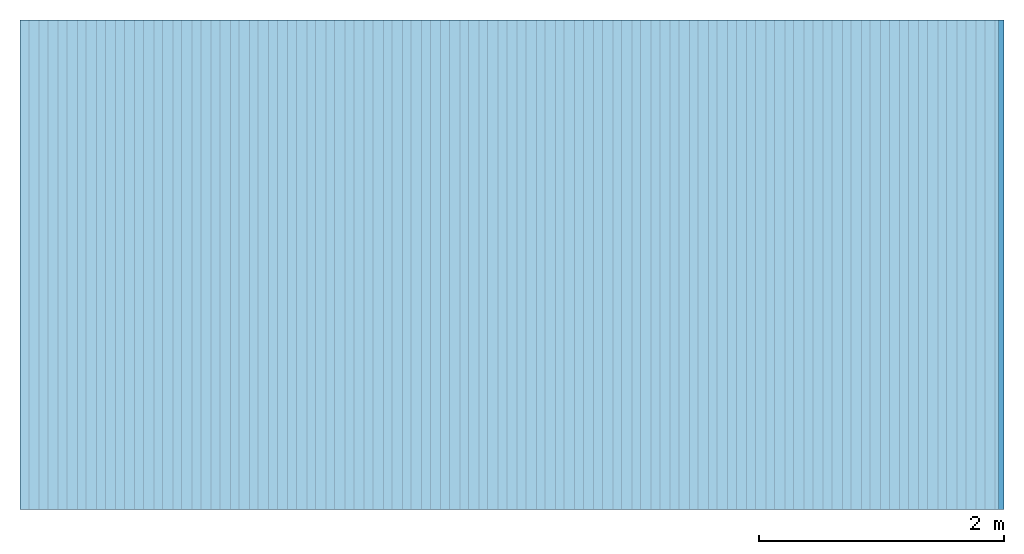
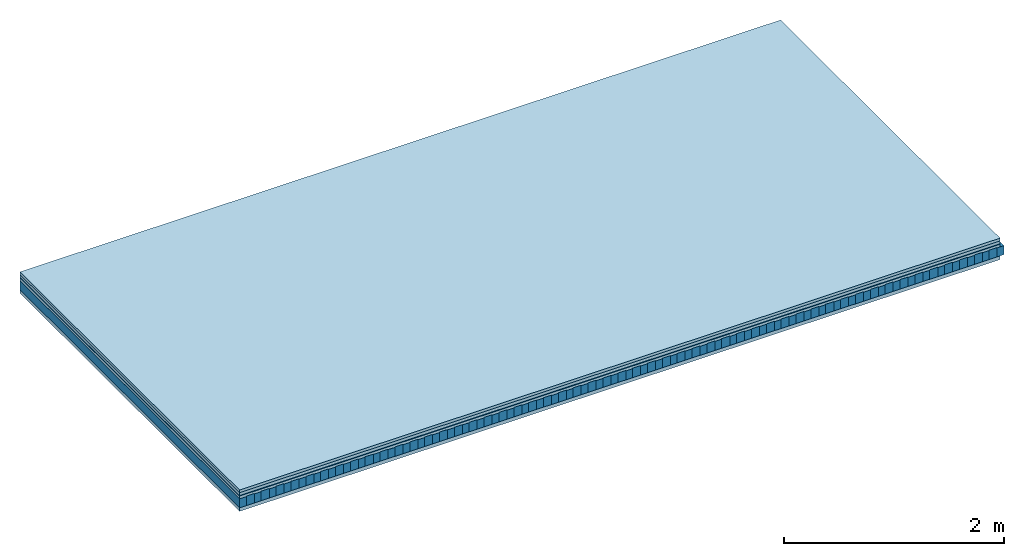
# One storey: 5 plates, 2 members, 1 element without a shape of its own.
"""IFC4 building model written with IfcOpenShell, lengths in metres."""

from ifc_helpers import new_model, si_unit, derived_unit, direction, frame, frame_2d, origin, origin_with_axes, place, context, project, spatial, rectangle, extrude, material, layer, layer_set, type_object, element, aggregate, save


model = new_model("IFC4")

# Units and contexts
plan_context = context("Plan", 3, precision=1e-05, world=origin(), true_north=direction((0.0, 1.0)))
model_context = context("Model", 3, precision=1e-05, world=origin(), true_north=direction((0.0, 1.0)))
ifc_project = project(units=[si_unit("LENGTHUNIT", "METRE"), derived_unit("SOUNDPRESSUREUNIT", [(si_unit("PRESSUREUNIT", "PASCAL", prefix="MICRO"), 0)]), si_unit("ENERGYUNIT", "JOULE", prefix="MEGA"), si_unit("MASSUNIT", "GRAM", prefix="KILO"), derived_unit("THERMALTRANSMITTANCEUNIT", [(si_unit("POWERUNIT", "WATT"), 1), (si_unit("AREAUNIT", "SQUARE_METRE"), -1), (si_unit("THERMODYNAMICTEMPERATUREUNIT", "KELVIN"), -1)]), derived_unit("AREADENSITYUNIT", [(si_unit("MASSUNIT", "GRAM", prefix="KILO"), 1), (si_unit("AREAUNIT", "SQUARE_METRE"), -1)]), derived_unit("USERDEFINED", [(si_unit("ENERGYUNIT", "JOULE", prefix="MEGA"), 1), (si_unit("AREAUNIT", "SQUARE_METRE"), -1)])], contexts=[plan_context, model_context])

# Site, building, storey
site = spatial("IfcSite", under=ifc_project)
building_placement = place(None, origin())
building = spatial("IfcBuilding", under=site, at=building_placement)
storey_placement = place(building_placement, origin())
storey = spatial("IfcBuildingStorey", under=building, at=storey_placement)

# Slab, members, plates
ifc_material_1 = material(Category="10.009")
ifc_layer_1 = layer(ifc_material_1, 0.03, Name="On-material")
ifc_material_2 = material(Name="32/30mm", Category="10.009")
ifc_layer_2 = layer(ifc_material_2, 0.032, Name="Impact sound insulation")
ifc_material_3 = material(Name="Step 6mm", Category="10.009")
ifc_layer_3 = layer(ifc_material_3, 0.006, Name="Additional insulation")
ifc_material_4 = material()
ifc_layer_4 = layer(ifc_material_4, 0.03, Name="Sub-floor")
ifc_material_5 = material(Name="Rigid, of the art")
ifc_layer_5 = layer(ifc_material_5, 0.0, Name="Bond")
ifc_layer_6 = layer(None, 0.1, Name="Supporting structure")
ifc_layer_7 = layer(ifc_material_5, 0.0, Name="Bond")
ifc_material_6 = material(Name="panel on the underside HBF 40mm (20+20mm)", Category="07.001")
ifc_layer_8 = layer(ifc_material_6, 0.04, Name="Lower layer 1")
ifc_layer_set = layer_set([ifc_layer_1, ifc_layer_2, ifc_layer_3, ifc_layer_4, ifc_layer_5, ifc_layer_6, ifc_layer_7, ifc_layer_8])
slab_type = type_object("IfcSlabType", Name="A0083", PredefinedType="NOTDEFINED", material=ifc_layer_set)
slab_placement = place(None, frame((0.0, 0.0, 0.0), z_axis=(0.0, 0.0, -1.0), x_axis=(1.0, 0.0, 0.0)))
slab = element("IfcSlab", 1, at=slab_placement, inside=storey, type_object=slab_type, material=ifc_layer_set, Name="Slab #1")
ifc_material_7 = material(Name="Block Q4")
member_1_placement = place(slab_placement, origin())
member_1 = element("IfcMember", 2, at=member_1_placement, material=ifc_material_7, Name="Supporting structure", context=plan_context, shape_type="SweptSolid", body=[
    extrude(rectangle(XDim=0.071666666666667, YDim=0.1, at=frame_2d((0.0358333333333335, 0.05), x_axis=(1.0, 0.0))), frame((0.0, 4.0, 0.098), z_axis=(0.0, -1.0, 0.0), x_axis=(1.0, 0.0, 0.0)), (0.0, 0.0, 1.0), 4.0),
    extrude(rectangle(XDim=0.071666666666667, YDim=0.1, at=frame_2d((0.0358333333333335, 0.05), x_axis=(1.0, 0.0))), frame((0.15625, 4.0, 0.098), z_axis=(0.0, -1.0, 0.0), x_axis=(1.0, 0.0, 0.0)), (0.0, 0.0, 1.0), 4.0),
    extrude(rectangle(XDim=0.071666666666667, YDim=0.1, at=frame_2d((0.0358333333333335, 0.05), x_axis=(1.0, 0.0))), frame((0.3125, 4.0, 0.098), z_axis=(0.0, -1.0, 0.0), x_axis=(1.0, 0.0, 0.0)), (0.0, 0.0, 1.0), 4.0),
    extrude(rectangle(XDim=0.071666666666667, YDim=0.1, at=frame_2d((0.0358333333333335, 0.05), x_axis=(1.0, 0.0))), frame((0.46875, 4.0, 0.098), z_axis=(0.0, -1.0, 0.0), x_axis=(1.0, 0.0, 0.0)), (0.0, 0.0, 1.0), 4.0),
    extrude(rectangle(XDim=0.071666666666667, YDim=0.1, at=frame_2d((0.0358333333333335, 0.05), x_axis=(1.0, 0.0))), frame((0.625, 4.0, 0.098), z_axis=(0.0, -1.0, 0.0), x_axis=(1.0, 0.0, 0.0)), (0.0, 0.0, 1.0), 4.0),
    extrude(rectangle(XDim=0.071666666666667, YDim=0.1, at=frame_2d((0.0358333333333335, 0.05), x_axis=(1.0, 0.0))), frame((0.78125, 4.0, 0.098), z_axis=(0.0, -1.0, 0.0), x_axis=(1.0, 0.0, 0.0)), (0.0, 0.0, 1.0), 4.0),
    extrude(rectangle(XDim=0.071666666666667, YDim=0.1, at=frame_2d((0.0358333333333335, 0.05), x_axis=(1.0, 0.0))), frame((0.9375, 4.0, 0.098), z_axis=(0.0, -1.0, 0.0), x_axis=(1.0, 0.0, 0.0)), (0.0, 0.0, 1.0), 4.0),
    extrude(rectangle(XDim=0.071666666666667, YDim=0.1, at=frame_2d((0.0358333333333335, 0.05), x_axis=(1.0, 0.0))), frame((1.09375, 4.0, 0.098), z_axis=(0.0, -1.0, 0.0), x_axis=(1.0, 0.0, 0.0)), (0.0, 0.0, 1.0), 4.0),
    extrude(rectangle(XDim=0.071666666666667, YDim=0.1, at=frame_2d((0.0358333333333335, 0.05), x_axis=(1.0, 0.0))), frame((1.25, 4.0, 0.098), z_axis=(0.0, -1.0, 0.0), x_axis=(1.0, 0.0, 0.0)), (0.0, 0.0, 1.0), 4.0),
    extrude(rectangle(XDim=0.071666666666667, YDim=0.1, at=frame_2d((0.0358333333333335, 0.05), x_axis=(1.0, 0.0))), frame((1.40625, 4.0, 0.098), z_axis=(0.0, -1.0, 0.0), x_axis=(1.0, 0.0, 0.0)), (0.0, 0.0, 1.0), 4.0),
    extrude(rectangle(XDim=0.071666666666667, YDim=0.1, at=frame_2d((0.0358333333333335, 0.05), x_axis=(1.0, 0.0))), frame((1.5625, 4.0, 0.098), z_axis=(0.0, -1.0, 0.0), x_axis=(1.0, 0.0, 0.0)), (0.0, 0.0, 1.0), 4.0),
    extrude(rectangle(XDim=0.071666666666667, YDim=0.1, at=frame_2d((0.0358333333333335, 0.05), x_axis=(1.0, 0.0))), frame((1.71875, 4.0, 0.098), z_axis=(0.0, -1.0, 0.0), x_axis=(1.0, 0.0, 0.0)), (0.0, 0.0, 1.0), 4.0),
    extrude(rectangle(XDim=0.071666666666667, YDim=0.1, at=frame_2d((0.0358333333333335, 0.05), x_axis=(1.0, 0.0))), frame((1.875, 4.0, 0.098), z_axis=(0.0, -1.0, 0.0), x_axis=(1.0, 0.0, 0.0)), (0.0, 0.0, 1.0), 4.0),
    extrude(rectangle(XDim=0.071666666666667, YDim=0.1, at=frame_2d((0.0358333333333335, 0.05), x_axis=(1.0, 0.0))), frame((2.03125, 4.0, 0.098), z_axis=(0.0, -1.0, 0.0), x_axis=(1.0, 0.0, 0.0)), (0.0, 0.0, 1.0), 4.0),
    extrude(rectangle(XDim=0.071666666666667, YDim=0.1, at=frame_2d((0.0358333333333335, 0.05), x_axis=(1.0, 0.0))), frame((2.1875, 4.0, 0.098), z_axis=(0.0, -1.0, 0.0), x_axis=(1.0, 0.0, 0.0)), (0.0, 0.0, 1.0), 4.0),
    extrude(rectangle(XDim=0.071666666666667, YDim=0.1, at=frame_2d((0.0358333333333335, 0.05), x_axis=(1.0, 0.0))), frame((2.34375, 4.0, 0.098), z_axis=(0.0, -1.0, 0.0), x_axis=(1.0, 0.0, 0.0)), (0.0, 0.0, 1.0), 4.0),
    extrude(rectangle(XDim=0.071666666666667, YDim=0.1, at=frame_2d((0.0358333333333335, 0.05), x_axis=(1.0, 0.0))), frame((2.5, 4.0, 0.098), z_axis=(0.0, -1.0, 0.0), x_axis=(1.0, 0.0, 0.0)), (0.0, 0.0, 1.0), 4.0),
    extrude(rectangle(XDim=0.071666666666667, YDim=0.1, at=frame_2d((0.0358333333333335, 0.05), x_axis=(1.0, 0.0))), frame((2.65625, 4.0, 0.098), z_axis=(0.0, -1.0, 0.0), x_axis=(1.0, 0.0, 0.0)), (0.0, 0.0, 1.0), 4.0),
    extrude(rectangle(XDim=0.071666666666667, YDim=0.1, at=frame_2d((0.0358333333333335, 0.05), x_axis=(1.0, 0.0))), frame((2.8125, 4.0, 0.098), z_axis=(0.0, -1.0, 0.0), x_axis=(1.0, 0.0, 0.0)), (0.0, 0.0, 1.0), 4.0),
    extrude(rectangle(XDim=0.071666666666667, YDim=0.1, at=frame_2d((0.0358333333333335, 0.05), x_axis=(1.0, 0.0))), frame((2.96875, 4.0, 0.098), z_axis=(0.0, -1.0, 0.0), x_axis=(1.0, 0.0, 0.0)), (0.0, 0.0, 1.0), 4.0),
    extrude(rectangle(XDim=0.071666666666667, YDim=0.1, at=frame_2d((0.0358333333333335, 0.05), x_axis=(1.0, 0.0))), frame((3.125, 4.0, 0.098), z_axis=(0.0, -1.0, 0.0), x_axis=(1.0, 0.0, 0.0)), (0.0, 0.0, 1.0), 4.0),
    extrude(rectangle(XDim=0.071666666666667, YDim=0.1, at=frame_2d((0.0358333333333335, 0.05), x_axis=(1.0, 0.0))), frame((3.28125, 4.0, 0.098), z_axis=(0.0, -1.0, 0.0), x_axis=(1.0, 0.0, 0.0)), (0.0, 0.0, 1.0), 4.0),
    extrude(rectangle(XDim=0.071666666666667, YDim=0.1, at=frame_2d((0.0358333333333335, 0.05), x_axis=(1.0, 0.0))), frame((3.4375, 4.0, 0.098), z_axis=(0.0, -1.0, 0.0), x_axis=(1.0, 0.0, 0.0)), (0.0, 0.0, 1.0), 4.0),
    extrude(rectangle(XDim=0.071666666666667, YDim=0.1, at=frame_2d((0.0358333333333335, 0.05), x_axis=(1.0, 0.0))), frame((3.59375, 4.0, 0.098), z_axis=(0.0, -1.0, 0.0), x_axis=(1.0, 0.0, 0.0)), (0.0, 0.0, 1.0), 4.0),
    extrude(rectangle(XDim=0.071666666666667, YDim=0.1, at=frame_2d((0.0358333333333335, 0.05), x_axis=(1.0, 0.0))), frame((3.75, 4.0, 0.098), z_axis=(0.0, -1.0, 0.0), x_axis=(1.0, 0.0, 0.0)), (0.0, 0.0, 1.0), 4.0),
    extrude(rectangle(XDim=0.071666666666667, YDim=0.1, at=frame_2d((0.0358333333333335, 0.05), x_axis=(1.0, 0.0))), frame((3.90625, 4.0, 0.098), z_axis=(0.0, -1.0, 0.0), x_axis=(1.0, 0.0, 0.0)), (0.0, 0.0, 1.0), 4.0),
    extrude(rectangle(XDim=0.071666666666667, YDim=0.1, at=frame_2d((0.0358333333333335, 0.05), x_axis=(1.0, 0.0))), frame((4.0625, 4.0, 0.098), z_axis=(0.0, -1.0, 0.0), x_axis=(1.0, 0.0, 0.0)), (0.0, 0.0, 1.0), 4.0),
    extrude(rectangle(XDim=0.071666666666667, YDim=0.1, at=frame_2d((0.0358333333333335, 0.05), x_axis=(1.0, 0.0))), frame((4.21875, 4.0, 0.098), z_axis=(0.0, -1.0, 0.0), x_axis=(1.0, 0.0, 0.0)), (0.0, 0.0, 1.0), 4.0),
    extrude(rectangle(XDim=0.071666666666667, YDim=0.1, at=frame_2d((0.0358333333333335, 0.05), x_axis=(1.0, 0.0))), frame((4.375, 4.0, 0.098), z_axis=(0.0, -1.0, 0.0), x_axis=(1.0, 0.0, 0.0)), (0.0, 0.0, 1.0), 4.0),
    extrude(rectangle(XDim=0.071666666666667, YDim=0.1, at=frame_2d((0.0358333333333335, 0.05), x_axis=(1.0, 0.0))), frame((4.53125, 4.0, 0.098), z_axis=(0.0, -1.0, 0.0), x_axis=(1.0, 0.0, 0.0)), (0.0, 0.0, 1.0), 4.0),
    extrude(rectangle(XDim=0.071666666666667, YDim=0.1, at=frame_2d((0.0358333333333335, 0.05), x_axis=(1.0, 0.0))), frame((4.6875, 4.0, 0.098), z_axis=(0.0, -1.0, 0.0), x_axis=(1.0, 0.0, 0.0)), (0.0, 0.0, 1.0), 4.0),
    extrude(rectangle(XDim=0.071666666666667, YDim=0.1, at=frame_2d((0.0358333333333335, 0.05), x_axis=(1.0, 0.0))), frame((4.84375, 4.0, 0.098), z_axis=(0.0, -1.0, 0.0), x_axis=(1.0, 0.0, 0.0)), (0.0, 0.0, 1.0), 4.0),
    extrude(rectangle(XDim=0.071666666666667, YDim=0.1, at=frame_2d((0.0358333333333335, 0.05), x_axis=(1.0, 0.0))), frame((5.0, 4.0, 0.098), z_axis=(0.0, -1.0, 0.0), x_axis=(1.0, 0.0, 0.0)), (0.0, 0.0, 1.0), 4.0),
    extrude(rectangle(XDim=0.071666666666667, YDim=0.1, at=frame_2d((0.0358333333333335, 0.05), x_axis=(1.0, 0.0))), frame((5.15625, 4.0, 0.098), z_axis=(0.0, -1.0, 0.0), x_axis=(1.0, 0.0, 0.0)), (0.0, 0.0, 1.0), 4.0),
    extrude(rectangle(XDim=0.071666666666667, YDim=0.1, at=frame_2d((0.0358333333333335, 0.05), x_axis=(1.0, 0.0))), frame((5.3125, 4.0, 0.098), z_axis=(0.0, -1.0, 0.0), x_axis=(1.0, 0.0, 0.0)), (0.0, 0.0, 1.0), 4.0),
    extrude(rectangle(XDim=0.071666666666667, YDim=0.1, at=frame_2d((0.0358333333333335, 0.05), x_axis=(1.0, 0.0))), frame((5.46875, 4.0, 0.098), z_axis=(0.0, -1.0, 0.0), x_axis=(1.0, 0.0, 0.0)), (0.0, 0.0, 1.0), 4.0),
    extrude(rectangle(XDim=0.071666666666667, YDim=0.1, at=frame_2d((0.0358333333333335, 0.05), x_axis=(1.0, 0.0))), frame((5.625, 4.0, 0.098), z_axis=(0.0, -1.0, 0.0), x_axis=(1.0, 0.0, 0.0)), (0.0, 0.0, 1.0), 4.0),
    extrude(rectangle(XDim=0.071666666666667, YDim=0.1, at=frame_2d((0.0358333333333335, 0.05), x_axis=(1.0, 0.0))), frame((5.78125, 4.0, 0.098), z_axis=(0.0, -1.0, 0.0), x_axis=(1.0, 0.0, 0.0)), (0.0, 0.0, 1.0), 4.0),
    extrude(rectangle(XDim=0.071666666666667, YDim=0.1, at=frame_2d((0.0358333333333335, 0.05), x_axis=(1.0, 0.0))), frame((5.9375, 4.0, 0.098), z_axis=(0.0, -1.0, 0.0), x_axis=(1.0, 0.0, 0.0)), (0.0, 0.0, 1.0), 4.0),
    extrude(rectangle(XDim=0.071666666666667, YDim=0.1, at=frame_2d((0.0358333333333335, 0.05), x_axis=(1.0, 0.0))), frame((6.09375, 4.0, 0.098), z_axis=(0.0, -1.0, 0.0), x_axis=(1.0, 0.0, 0.0)), (0.0, 0.0, 1.0), 4.0),
    extrude(rectangle(XDim=0.071666666666667, YDim=0.1, at=frame_2d((0.0358333333333335, 0.05), x_axis=(1.0, 0.0))), frame((6.25, 4.0, 0.098), z_axis=(0.0, -1.0, 0.0), x_axis=(1.0, 0.0, 0.0)), (0.0, 0.0, 1.0), 4.0),
    extrude(rectangle(XDim=0.071666666666667, YDim=0.1, at=frame_2d((0.0358333333333335, 0.05), x_axis=(1.0, 0.0))), frame((6.40625, 4.0, 0.098), z_axis=(0.0, -1.0, 0.0), x_axis=(1.0, 0.0, 0.0)), (0.0, 0.0, 1.0), 4.0),
    extrude(rectangle(XDim=0.071666666666667, YDim=0.1, at=frame_2d((0.0358333333333335, 0.05), x_axis=(1.0, 0.0))), frame((6.5625, 4.0, 0.098), z_axis=(0.0, -1.0, 0.0), x_axis=(1.0, 0.0, 0.0)), (0.0, 0.0, 1.0), 4.0),
    extrude(rectangle(XDim=0.071666666666667, YDim=0.1, at=frame_2d((0.0358333333333335, 0.05), x_axis=(1.0, 0.0))), frame((6.71875, 4.0, 0.098), z_axis=(0.0, -1.0, 0.0), x_axis=(1.0, 0.0, 0.0)), (0.0, 0.0, 1.0), 4.0),
    extrude(rectangle(XDim=0.071666666666667, YDim=0.1, at=frame_2d((0.0358333333333335, 0.05), x_axis=(1.0, 0.0))), frame((6.875, 4.0, 0.098), z_axis=(0.0, -1.0, 0.0), x_axis=(1.0, 0.0, 0.0)), (0.0, 0.0, 1.0), 4.0),
    extrude(rectangle(XDim=0.071666666666667, YDim=0.1, at=frame_2d((0.0358333333333335, 0.05), x_axis=(1.0, 0.0))), frame((7.03125, 4.0, 0.098), z_axis=(0.0, -1.0, 0.0), x_axis=(1.0, 0.0, 0.0)), (0.0, 0.0, 1.0), 4.0),
    extrude(rectangle(XDim=0.071666666666667, YDim=0.1, at=frame_2d((0.0358333333333335, 0.05), x_axis=(1.0, 0.0))), frame((7.1875, 4.0, 0.098), z_axis=(0.0, -1.0, 0.0), x_axis=(1.0, 0.0, 0.0)), (0.0, 0.0, 1.0), 4.0),
    extrude(rectangle(XDim=0.071666666666667, YDim=0.1, at=frame_2d((0.0358333333333335, 0.05), x_axis=(1.0, 0.0))), frame((7.34375, 4.0, 0.098), z_axis=(0.0, -1.0, 0.0), x_axis=(1.0, 0.0, 0.0)), (0.0, 0.0, 1.0), 4.0),
    extrude(rectangle(XDim=0.071666666666667, YDim=0.1, at=frame_2d((0.0358333333333335, 0.05), x_axis=(1.0, 0.0))), frame((7.5, 4.0, 0.098), z_axis=(0.0, -1.0, 0.0), x_axis=(1.0, 0.0, 0.0)), (0.0, 0.0, 1.0), 4.0),
    extrude(rectangle(XDim=0.071666666666667, YDim=0.1, at=frame_2d((0.0358333333333335, 0.05), x_axis=(1.0, 0.0))), frame((7.65625, 4.0, 0.098), z_axis=(0.0, -1.0, 0.0), x_axis=(1.0, 0.0, 0.0)), (0.0, 0.0, 1.0), 4.0),
    extrude(rectangle(XDim=0.071666666666667, YDim=0.1, at=frame_2d((0.0358333333333335, 0.05), x_axis=(1.0, 0.0))), frame((7.8125, 4.0, 0.098), z_axis=(0.0, -1.0, 0.0), x_axis=(1.0, 0.0, 0.0)), (0.0, 0.0, 1.0), 4.0),
    extrude(rectangle(XDim=0.071666666666667, YDim=0.1, at=frame_2d((0.0358333333333335, 0.05), x_axis=(1.0, 0.0))), frame((7.96875, 4.0, 0.098), z_axis=(0.0, -1.0, 0.0), x_axis=(1.0, 0.0, 0.0)), (0.0, 0.0, 1.0), 4.0),
])
ifc_material_8 = material()
member_2_placement = place(slab_placement, origin())
member_2 = element("IfcMember", 3, at=member_2_placement, material=ifc_material_8, Name="in supporting structure", context=plan_context, shape_type="SweptSolid", body=[
    extrude(rectangle(XDim=0.084583333333333, YDim=0.105, at=frame_2d((0.0422916666666665, 0.0525), x_axis=(1.0, 0.0))), frame((0.071666666666667, 4.0, 0.093), z_axis=(0.0, -1.0, 0.0), x_axis=(1.0, 0.0, 0.0)), (0.0, 0.0, 1.0), 4.0),
    extrude(rectangle(XDim=0.084583333333333, YDim=0.105, at=frame_2d((0.0422916666666665, 0.0525), x_axis=(1.0, 0.0))), frame((0.227916666666667, 4.0, 0.093), z_axis=(0.0, -1.0, 0.0), x_axis=(1.0, 0.0, 0.0)), (0.0, 0.0, 1.0), 4.0),
    extrude(rectangle(XDim=0.084583333333333, YDim=0.105, at=frame_2d((0.0422916666666665, 0.0525), x_axis=(1.0, 0.0))), frame((0.384166666666667, 4.0, 0.093), z_axis=(0.0, -1.0, 0.0), x_axis=(1.0, 0.0, 0.0)), (0.0, 0.0, 1.0), 4.0),
    extrude(rectangle(XDim=0.084583333333333, YDim=0.105, at=frame_2d((0.0422916666666665, 0.0525), x_axis=(1.0, 0.0))), frame((0.540416666666667, 4.0, 0.093), z_axis=(0.0, -1.0, 0.0), x_axis=(1.0, 0.0, 0.0)), (0.0, 0.0, 1.0), 4.0),
    extrude(rectangle(XDim=0.084583333333333, YDim=0.105, at=frame_2d((0.0422916666666665, 0.0525), x_axis=(1.0, 0.0))), frame((0.696666666666667, 4.0, 0.093), z_axis=(0.0, -1.0, 0.0), x_axis=(1.0, 0.0, 0.0)), (0.0, 0.0, 1.0), 4.0),
    extrude(rectangle(XDim=0.084583333333333, YDim=0.105, at=frame_2d((0.0422916666666665, 0.0525), x_axis=(1.0, 0.0))), frame((0.852916666666667, 4.0, 0.093), z_axis=(0.0, -1.0, 0.0), x_axis=(1.0, 0.0, 0.0)), (0.0, 0.0, 1.0), 4.0),
    extrude(rectangle(XDim=0.084583333333333, YDim=0.105, at=frame_2d((0.0422916666666665, 0.0525), x_axis=(1.0, 0.0))), frame((1.00916666666667, 4.0, 0.093), z_axis=(0.0, -1.0, 0.0), x_axis=(1.0, 0.0, 0.0)), (0.0, 0.0, 1.0), 4.0),
    extrude(rectangle(XDim=0.084583333333333, YDim=0.105, at=frame_2d((0.0422916666666665, 0.0525), x_axis=(1.0, 0.0))), frame((1.16541666666667, 4.0, 0.093), z_axis=(0.0, -1.0, 0.0), x_axis=(1.0, 0.0, 0.0)), (0.0, 0.0, 1.0), 4.0),
    extrude(rectangle(XDim=0.084583333333333, YDim=0.105, at=frame_2d((0.0422916666666665, 0.0525), x_axis=(1.0, 0.0))), frame((1.32166666666667, 4.0, 0.093), z_axis=(0.0, -1.0, 0.0), x_axis=(1.0, 0.0, 0.0)), (0.0, 0.0, 1.0), 4.0),
    extrude(rectangle(XDim=0.084583333333333, YDim=0.105, at=frame_2d((0.0422916666666665, 0.0525), x_axis=(1.0, 0.0))), frame((1.47791666666667, 4.0, 0.093), z_axis=(0.0, -1.0, 0.0), x_axis=(1.0, 0.0, 0.0)), (0.0, 0.0, 1.0), 4.0),
    extrude(rectangle(XDim=0.084583333333333, YDim=0.105, at=frame_2d((0.0422916666666665, 0.0525), x_axis=(1.0, 0.0))), frame((1.63416666666667, 4.0, 0.093), z_axis=(0.0, -1.0, 0.0), x_axis=(1.0, 0.0, 0.0)), (0.0, 0.0, 1.0), 4.0),
    extrude(rectangle(XDim=0.084583333333333, YDim=0.105, at=frame_2d((0.0422916666666665, 0.0525), x_axis=(1.0, 0.0))), frame((1.79041666666667, 4.0, 0.093), z_axis=(0.0, -1.0, 0.0), x_axis=(1.0, 0.0, 0.0)), (0.0, 0.0, 1.0), 4.0),
    extrude(rectangle(XDim=0.084583333333333, YDim=0.105, at=frame_2d((0.0422916666666665, 0.0525), x_axis=(1.0, 0.0))), frame((1.94666666666667, 4.0, 0.093), z_axis=(0.0, -1.0, 0.0), x_axis=(1.0, 0.0, 0.0)), (0.0, 0.0, 1.0), 4.0),
    extrude(rectangle(XDim=0.084583333333333, YDim=0.105, at=frame_2d((0.0422916666666665, 0.0525), x_axis=(1.0, 0.0))), frame((2.10291666666667, 4.0, 0.093), z_axis=(0.0, -1.0, 0.0), x_axis=(1.0, 0.0, 0.0)), (0.0, 0.0, 1.0), 4.0),
    extrude(rectangle(XDim=0.084583333333333, YDim=0.105, at=frame_2d((0.0422916666666665, 0.0525), x_axis=(1.0, 0.0))), frame((2.25916666666667, 4.0, 0.093), z_axis=(0.0, -1.0, 0.0), x_axis=(1.0, 0.0, 0.0)), (0.0, 0.0, 1.0), 4.0),
    extrude(rectangle(XDim=0.084583333333333, YDim=0.105, at=frame_2d((0.0422916666666665, 0.0525), x_axis=(1.0, 0.0))), frame((2.41541666666667, 4.0, 0.093), z_axis=(0.0, -1.0, 0.0), x_axis=(1.0, 0.0, 0.0)), (0.0, 0.0, 1.0), 4.0),
    extrude(rectangle(XDim=0.084583333333333, YDim=0.105, at=frame_2d((0.0422916666666665, 0.0525), x_axis=(1.0, 0.0))), frame((2.57166666666667, 4.0, 0.093), z_axis=(0.0, -1.0, 0.0), x_axis=(1.0, 0.0, 0.0)), (0.0, 0.0, 1.0), 4.0),
    extrude(rectangle(XDim=0.084583333333333, YDim=0.105, at=frame_2d((0.0422916666666665, 0.0525), x_axis=(1.0, 0.0))), frame((2.72791666666667, 4.0, 0.093), z_axis=(0.0, -1.0, 0.0), x_axis=(1.0, 0.0, 0.0)), (0.0, 0.0, 1.0), 4.0),
    extrude(rectangle(XDim=0.084583333333333, YDim=0.105, at=frame_2d((0.0422916666666665, 0.0525), x_axis=(1.0, 0.0))), frame((2.88416666666667, 4.0, 0.093), z_axis=(0.0, -1.0, 0.0), x_axis=(1.0, 0.0, 0.0)), (0.0, 0.0, 1.0), 4.0),
    extrude(rectangle(XDim=0.084583333333333, YDim=0.105, at=frame_2d((0.0422916666666665, 0.0525), x_axis=(1.0, 0.0))), frame((3.04041666666667, 4.0, 0.093), z_axis=(0.0, -1.0, 0.0), x_axis=(1.0, 0.0, 0.0)), (0.0, 0.0, 1.0), 4.0),
    extrude(rectangle(XDim=0.084583333333333, YDim=0.105, at=frame_2d((0.0422916666666665, 0.0525), x_axis=(1.0, 0.0))), frame((3.19666666666667, 4.0, 0.093), z_axis=(0.0, -1.0, 0.0), x_axis=(1.0, 0.0, 0.0)), (0.0, 0.0, 1.0), 4.0),
    extrude(rectangle(XDim=0.084583333333333, YDim=0.105, at=frame_2d((0.0422916666666665, 0.0525), x_axis=(1.0, 0.0))), frame((3.35291666666667, 4.0, 0.093), z_axis=(0.0, -1.0, 0.0), x_axis=(1.0, 0.0, 0.0)), (0.0, 0.0, 1.0), 4.0),
    extrude(rectangle(XDim=0.084583333333333, YDim=0.105, at=frame_2d((0.0422916666666665, 0.0525), x_axis=(1.0, 0.0))), frame((3.50916666666667, 4.0, 0.093), z_axis=(0.0, -1.0, 0.0), x_axis=(1.0, 0.0, 0.0)), (0.0, 0.0, 1.0), 4.0),
    extrude(rectangle(XDim=0.084583333333333, YDim=0.105, at=frame_2d((0.0422916666666665, 0.0525), x_axis=(1.0, 0.0))), frame((3.66541666666667, 4.0, 0.093), z_axis=(0.0, -1.0, 0.0), x_axis=(1.0, 0.0, 0.0)), (0.0, 0.0, 1.0), 4.0),
    extrude(rectangle(XDim=0.084583333333333, YDim=0.105, at=frame_2d((0.0422916666666665, 0.0525), x_axis=(1.0, 0.0))), frame((3.82166666666667, 4.0, 0.093), z_axis=(0.0, -1.0, 0.0), x_axis=(1.0, 0.0, 0.0)), (0.0, 0.0, 1.0), 4.0),
    extrude(rectangle(XDim=0.084583333333333, YDim=0.105, at=frame_2d((0.0422916666666665, 0.0525), x_axis=(1.0, 0.0))), frame((3.97791666666667, 4.0, 0.093), z_axis=(0.0, -1.0, 0.0), x_axis=(1.0, 0.0, 0.0)), (0.0, 0.0, 1.0), 4.0),
    extrude(rectangle(XDim=0.084583333333333, YDim=0.105, at=frame_2d((0.0422916666666665, 0.0525), x_axis=(1.0, 0.0))), frame((4.13416666666667, 4.0, 0.093), z_axis=(0.0, -1.0, 0.0), x_axis=(1.0, 0.0, 0.0)), (0.0, 0.0, 1.0), 4.0),
    extrude(rectangle(XDim=0.084583333333333, YDim=0.105, at=frame_2d((0.0422916666666665, 0.0525), x_axis=(1.0, 0.0))), frame((4.29041666666667, 4.0, 0.093), z_axis=(0.0, -1.0, 0.0), x_axis=(1.0, 0.0, 0.0)), (0.0, 0.0, 1.0), 4.0),
    extrude(rectangle(XDim=0.084583333333333, YDim=0.105, at=frame_2d((0.0422916666666665, 0.0525), x_axis=(1.0, 0.0))), frame((4.44666666666667, 4.0, 0.093), z_axis=(0.0, -1.0, 0.0), x_axis=(1.0, 0.0, 0.0)), (0.0, 0.0, 1.0), 4.0),
    extrude(rectangle(XDim=0.084583333333333, YDim=0.105, at=frame_2d((0.0422916666666665, 0.0525), x_axis=(1.0, 0.0))), frame((4.60291666666667, 4.0, 0.093), z_axis=(0.0, -1.0, 0.0), x_axis=(1.0, 0.0, 0.0)), (0.0, 0.0, 1.0), 4.0),
    extrude(rectangle(XDim=0.084583333333333, YDim=0.105, at=frame_2d((0.0422916666666665, 0.0525), x_axis=(1.0, 0.0))), frame((4.75916666666667, 4.0, 0.093), z_axis=(0.0, -1.0, 0.0), x_axis=(1.0, 0.0, 0.0)), (0.0, 0.0, 1.0), 4.0),
    extrude(rectangle(XDim=0.084583333333333, YDim=0.105, at=frame_2d((0.0422916666666665, 0.0525), x_axis=(1.0, 0.0))), frame((4.91541666666667, 4.0, 0.093), z_axis=(0.0, -1.0, 0.0), x_axis=(1.0, 0.0, 0.0)), (0.0, 0.0, 1.0), 4.0),
    extrude(rectangle(XDim=0.084583333333333, YDim=0.105, at=frame_2d((0.0422916666666665, 0.0525), x_axis=(1.0, 0.0))), frame((5.07166666666667, 4.0, 0.093), z_axis=(0.0, -1.0, 0.0), x_axis=(1.0, 0.0, 0.0)), (0.0, 0.0, 1.0), 4.0),
    extrude(rectangle(XDim=0.084583333333333, YDim=0.105, at=frame_2d((0.0422916666666665, 0.0525), x_axis=(1.0, 0.0))), frame((5.22791666666667, 4.0, 0.093), z_axis=(0.0, -1.0, 0.0), x_axis=(1.0, 0.0, 0.0)), (0.0, 0.0, 1.0), 4.0),
    extrude(rectangle(XDim=0.084583333333333, YDim=0.105, at=frame_2d((0.0422916666666665, 0.0525), x_axis=(1.0, 0.0))), frame((5.38416666666667, 4.0, 0.093), z_axis=(0.0, -1.0, 0.0), x_axis=(1.0, 0.0, 0.0)), (0.0, 0.0, 1.0), 4.0),
    extrude(rectangle(XDim=0.084583333333333, YDim=0.105, at=frame_2d((0.0422916666666665, 0.0525), x_axis=(1.0, 0.0))), frame((5.54041666666667, 4.0, 0.093), z_axis=(0.0, -1.0, 0.0), x_axis=(1.0, 0.0, 0.0)), (0.0, 0.0, 1.0), 4.0),
    extrude(rectangle(XDim=0.084583333333333, YDim=0.105, at=frame_2d((0.0422916666666665, 0.0525), x_axis=(1.0, 0.0))), frame((5.69666666666667, 4.0, 0.093), z_axis=(0.0, -1.0, 0.0), x_axis=(1.0, 0.0, 0.0)), (0.0, 0.0, 1.0), 4.0),
    extrude(rectangle(XDim=0.084583333333333, YDim=0.105, at=frame_2d((0.0422916666666665, 0.0525), x_axis=(1.0, 0.0))), frame((5.85291666666667, 4.0, 0.093), z_axis=(0.0, -1.0, 0.0), x_axis=(1.0, 0.0, 0.0)), (0.0, 0.0, 1.0), 4.0),
    extrude(rectangle(XDim=0.084583333333333, YDim=0.105, at=frame_2d((0.0422916666666665, 0.0525), x_axis=(1.0, 0.0))), frame((6.00916666666667, 4.0, 0.093), z_axis=(0.0, -1.0, 0.0), x_axis=(1.0, 0.0, 0.0)), (0.0, 0.0, 1.0), 4.0),
    extrude(rectangle(XDim=0.084583333333333, YDim=0.105, at=frame_2d((0.0422916666666665, 0.0525), x_axis=(1.0, 0.0))), frame((6.16541666666667, 4.0, 0.093), z_axis=(0.0, -1.0, 0.0), x_axis=(1.0, 0.0, 0.0)), (0.0, 0.0, 1.0), 4.0),
    extrude(rectangle(XDim=0.084583333333333, YDim=0.105, at=frame_2d((0.0422916666666665, 0.0525), x_axis=(1.0, 0.0))), frame((6.32166666666667, 4.0, 0.093), z_axis=(0.0, -1.0, 0.0), x_axis=(1.0, 0.0, 0.0)), (0.0, 0.0, 1.0), 4.0),
    extrude(rectangle(XDim=0.084583333333333, YDim=0.105, at=frame_2d((0.0422916666666665, 0.0525), x_axis=(1.0, 0.0))), frame((6.47791666666667, 4.0, 0.093), z_axis=(0.0, -1.0, 0.0), x_axis=(1.0, 0.0, 0.0)), (0.0, 0.0, 1.0), 4.0),
    extrude(rectangle(XDim=0.084583333333333, YDim=0.105, at=frame_2d((0.0422916666666665, 0.0525), x_axis=(1.0, 0.0))), frame((6.63416666666667, 4.0, 0.093), z_axis=(0.0, -1.0, 0.0), x_axis=(1.0, 0.0, 0.0)), (0.0, 0.0, 1.0), 4.0),
    extrude(rectangle(XDim=0.084583333333333, YDim=0.105, at=frame_2d((0.0422916666666665, 0.0525), x_axis=(1.0, 0.0))), frame((6.79041666666667, 4.0, 0.093), z_axis=(0.0, -1.0, 0.0), x_axis=(1.0, 0.0, 0.0)), (0.0, 0.0, 1.0), 4.0),
    extrude(rectangle(XDim=0.084583333333333, YDim=0.105, at=frame_2d((0.0422916666666665, 0.0525), x_axis=(1.0, 0.0))), frame((6.94666666666667, 4.0, 0.093), z_axis=(0.0, -1.0, 0.0), x_axis=(1.0, 0.0, 0.0)), (0.0, 0.0, 1.0), 4.0),
    extrude(rectangle(XDim=0.084583333333333, YDim=0.105, at=frame_2d((0.0422916666666665, 0.0525), x_axis=(1.0, 0.0))), frame((7.10291666666667, 4.0, 0.093), z_axis=(0.0, -1.0, 0.0), x_axis=(1.0, 0.0, 0.0)), (0.0, 0.0, 1.0), 4.0),
    extrude(rectangle(XDim=0.084583333333333, YDim=0.105, at=frame_2d((0.0422916666666665, 0.0525), x_axis=(1.0, 0.0))), frame((7.25916666666667, 4.0, 0.093), z_axis=(0.0, -1.0, 0.0), x_axis=(1.0, 0.0, 0.0)), (0.0, 0.0, 1.0), 4.0),
    extrude(rectangle(XDim=0.084583333333333, YDim=0.105, at=frame_2d((0.0422916666666665, 0.0525), x_axis=(1.0, 0.0))), frame((7.41541666666667, 4.0, 0.093), z_axis=(0.0, -1.0, 0.0), x_axis=(1.0, 0.0, 0.0)), (0.0, 0.0, 1.0), 4.0),
    extrude(rectangle(XDim=0.084583333333333, YDim=0.105, at=frame_2d((0.0422916666666665, 0.0525), x_axis=(1.0, 0.0))), frame((7.57166666666667, 4.0, 0.093), z_axis=(0.0, -1.0, 0.0), x_axis=(1.0, 0.0, 0.0)), (0.0, 0.0, 1.0), 4.0),
    extrude(rectangle(XDim=0.084583333333333, YDim=0.105, at=frame_2d((0.0422916666666665, 0.0525), x_axis=(1.0, 0.0))), frame((7.72791666666667, 4.0, 0.093), z_axis=(0.0, -1.0, 0.0), x_axis=(1.0, 0.0, 0.0)), (0.0, 0.0, 1.0), 4.0),
    extrude(rectangle(XDim=0.084583333333333, YDim=0.105, at=frame_2d((0.0422916666666665, 0.0525), x_axis=(1.0, 0.0))), frame((7.88416666666667, 4.0, 0.093), z_axis=(0.0, -1.0, 0.0), x_axis=(1.0, 0.0, 0.0)), (0.0, 0.0, 1.0), 4.0),
])
plate_1_placement = place(slab_placement, origin())
plate_1 = element("IfcPlate", 4, at=plate_1_placement, material=ifc_material_1, Name="On-material", context=plan_context, shape_type="SweptSolid", body=[
    extrude(rectangle(XDim=8.0, YDim=4.0, at=frame_2d((4.0, 2.0), x_axis=(1.0, 0.0))), origin_with_axes(), (0.0, 0.0, 1.0), 0.03),
])
plate_2_placement = place(slab_placement, origin())
plate_2 = element("IfcPlate", 5, at=plate_2_placement, material=ifc_material_2, Name="Impact sound insulation", context=plan_context, shape_type="SweptSolid", body=[
    extrude(rectangle(XDim=8.0, YDim=4.0, at=frame_2d((4.0, 2.0), x_axis=(1.0, 0.0))), frame((0.0, 0.0, 0.03), z_axis=(0.0, 0.0, 1.0), x_axis=(1.0, 0.0, 0.0)), (0.0, 0.0, 1.0), 0.032),
])
plate_3_placement = place(slab_placement, origin())
plate_3 = element("IfcPlate", 6, at=plate_3_placement, material=ifc_material_3, Name="Additional insulation", context=plan_context, shape_type="SweptSolid", body=[
    extrude(rectangle(XDim=8.0, YDim=4.0, at=frame_2d((4.0, 2.0), x_axis=(1.0, 0.0))), frame((0.0, 0.0, 0.062), z_axis=(0.0, 0.0, 1.0), x_axis=(1.0, 0.0, 0.0)), (0.0, 0.0, 1.0), 0.006),
])
plate_4_placement = place(slab_placement, origin())
plate_4 = element("IfcPlate", 7, at=plate_4_placement, material=ifc_material_4, Name="Sub-floor", context=plan_context, shape_type="SweptSolid", body=[
    extrude(rectangle(XDim=8.0, YDim=4.0, at=frame_2d((4.0, 2.0), x_axis=(1.0, 0.0))), frame((0.0, 0.0, 0.068), z_axis=(0.0, 0.0, 1.0), x_axis=(1.0, 0.0, 0.0)), (0.0, 0.0, 1.0), 0.03),
])
plate_5_placement = place(slab_placement, origin())
plate_5 = element("IfcPlate", 8, at=plate_5_placement, material=ifc_material_6, Name="Lower layer 1", context=plan_context, shape_type="SweptSolid", body=[
    extrude(rectangle(XDim=8.0, YDim=4.0, at=frame_2d((4.0, 2.0), x_axis=(1.0, 0.0))), frame((0.0, 0.0, 0.198), z_axis=(0.0, 0.0, 1.0), x_axis=(1.0, 0.0, 0.0)), (0.0, 0.0, 1.0), 0.04),
])
aggregate(slab, [plate_1, plate_2, plate_3, plate_4, member_1, member_2, plate_5])

save(model, "model.ifc")
